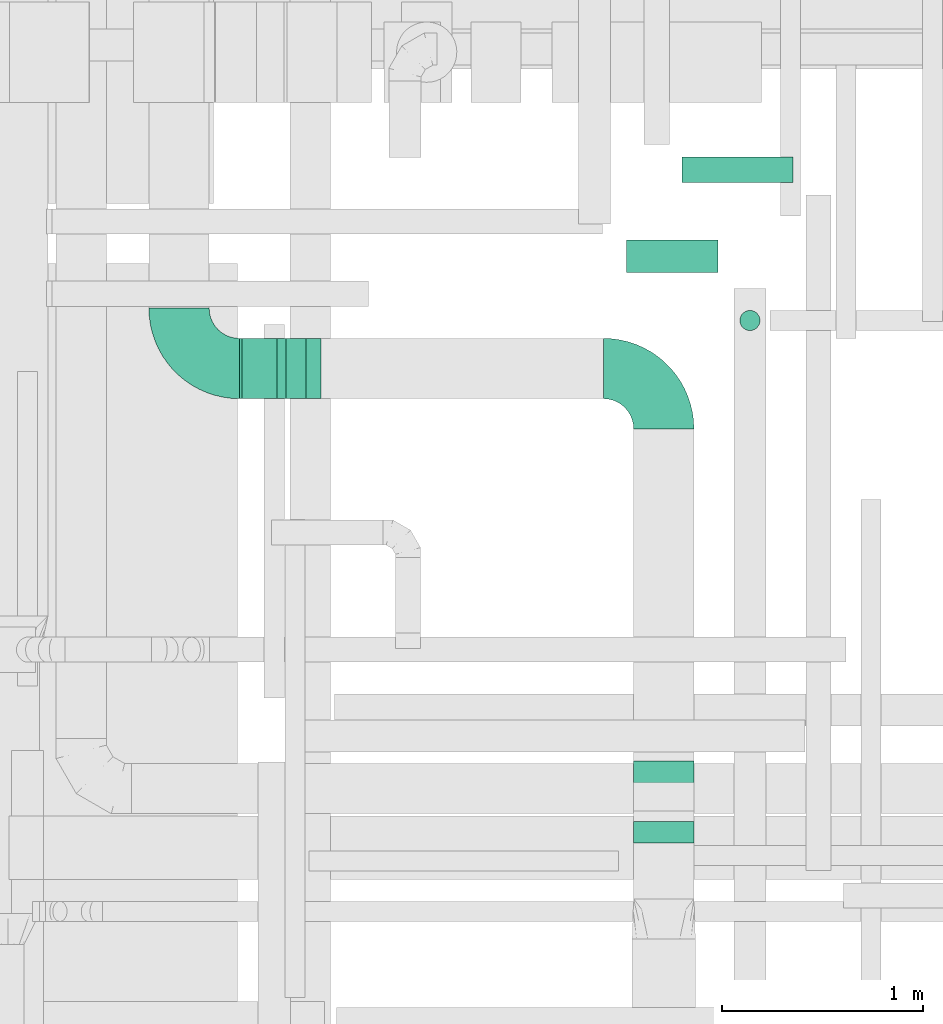
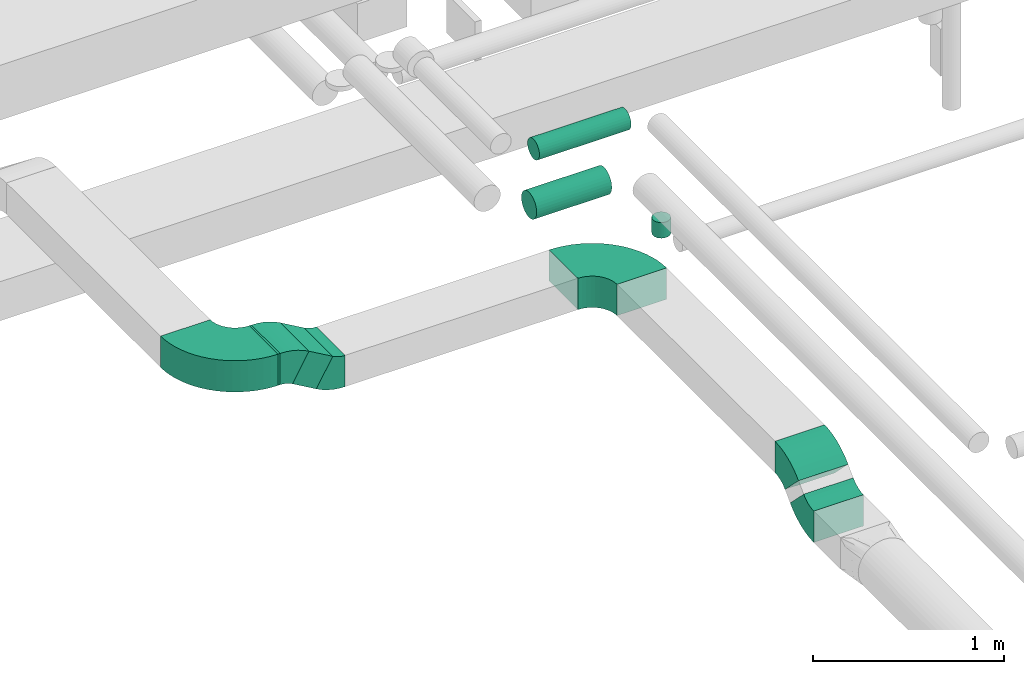
# One storey, part 125 of 337: 6 flow fittings, 5 flow segments.
"""IFC2X3 building model written with IfcOpenShell, lengths in millimetres."""

from ifc_helpers import new_model, entity, si_unit, converted_unit, derived_unit, direction, frame, frame_2d, origin, origin_2d_with_axis, place, context, subcontext, project, spatial, polyline, circle_curve, parameter, trimmed, segment, composite_curve, rectangle, circle, outline, extrude, source, transform, mapped, material, type_object, type_shapes, element, save


model = new_model("IFC2X3")

# Units and contexts
model_context = context("Model", 3, precision=0.01, world=origin(), true_north=direction((6.12303176911189e-17, 1.0)))
body_context = subcontext(model_context, "Body", "Model", "MODEL_VIEW")
ifc_project = project(units=[si_unit("LENGTHUNIT", "METRE", prefix="MILLI"), si_unit("AREAUNIT", "SQUARE_METRE"), si_unit("VOLUMEUNIT", "CUBIC_METRE"), converted_unit("PLANEANGLEUNIT", "DEGREE", entity("IfcRatioMeasure", 0.0174532925199433), si_unit("PLANEANGLEUNIT", "RADIAN"), dimensions=[0, 0, 0, 0, 0, 0, 0]), si_unit("MASSUNIT", "GRAM", prefix="KILO"), derived_unit("MASSDENSITYUNIT", [(si_unit("MASSUNIT", "GRAM", prefix="KILO"), 1), (si_unit("LENGTHUNIT", "METRE"), -3)]), derived_unit("MOMENTOFINERTIAUNIT", [(si_unit("LENGTHUNIT", "METRE"), 4)]), si_unit("TIMEUNIT", "SECOND"), si_unit("FREQUENCYUNIT", "HERTZ"), si_unit("THERMODYNAMICTEMPERATUREUNIT", "DEGREE_CELSIUS"), derived_unit("THERMALTRANSMITTANCEUNIT", [(si_unit("MASSUNIT", "GRAM", prefix="KILO"), 1), (si_unit("THERMODYNAMICTEMPERATUREUNIT", "KELVIN"), -1), (si_unit("TIMEUNIT", "SECOND"), -3)]), derived_unit("VOLUMETRICFLOWRATEUNIT", [(si_unit("LENGTHUNIT", "METRE"), 3), (si_unit("TIMEUNIT", "SECOND"), -1)]), derived_unit("MASSFLOWRATEUNIT", [(si_unit("MASSUNIT", "GRAM", prefix="KILO"), 1), (si_unit("TIMEUNIT", "SECOND"), -1)]), derived_unit("ROTATIONALFREQUENCYUNIT", [(si_unit("TIMEUNIT", "SECOND"), -1)]), si_unit("ELECTRICCURRENTUNIT", "AMPERE"), si_unit("ELECTRICVOLTAGEUNIT", "VOLT"), si_unit("POWERUNIT", "WATT"), si_unit("FORCEUNIT", "NEWTON", prefix="KILO"), si_unit("ILLUMINANCEUNIT", "LUX"), si_unit("LUMINOUSFLUXUNIT", "LUMEN"), si_unit("LUMINOUSINTENSITYUNIT", "CANDELA"), derived_unit("USERDEFINED", [(si_unit("MASSUNIT", "GRAM", prefix="KILO"), -1), (si_unit("LENGTHUNIT", "METRE"), -2), (si_unit("TIMEUNIT", "SECOND"), 3), (si_unit("LUMINOUSFLUXUNIT", "LUMEN"), 1)]), derived_unit("LINEARVELOCITYUNIT", [(si_unit("LENGTHUNIT", "METRE"), 1), (si_unit("TIMEUNIT", "SECOND"), -1)]), si_unit("PRESSUREUNIT", "PASCAL"), derived_unit("USERDEFINED", [(si_unit("LENGTHUNIT", "METRE"), -2), (si_unit("MASSUNIT", "GRAM", prefix="KILO"), 1), (si_unit("TIMEUNIT", "SECOND"), -2)]), derived_unit("LINEARFORCEUNIT", [(si_unit("MASSUNIT", "GRAM", prefix="KILO"), 1), (si_unit("LENGTHUNIT", "METRE"), 1), (si_unit("TIMEUNIT", "SECOND"), -2), (si_unit("LENGTHUNIT", "METRE"), -1)]), derived_unit("PLANARFORCEUNIT", [(si_unit("MASSUNIT", "GRAM", prefix="KILO"), 1), (si_unit("LENGTHUNIT", "METRE"), 1), (si_unit("TIMEUNIT", "SECOND"), -2), (si_unit("LENGTHUNIT", "METRE"), -2)])], contexts=[model_context])

# Site, building, storey
site_placement = place(None, origin())
site = spatial("IfcSite", under=ifc_project, at=site_placement, CompositionType="ELEMENT")
building_placement = place(site_placement, origin())
building = spatial("IfcBuilding", under=site, at=building_placement, CompositionType="ELEMENT")
storey_placement = place(building_placement, origin())
storey = spatial("IfcBuildingStorey", under=building, at=storey_placement, CompositionType="ELEMENT", Elevation=0.0)

# Flow segments
duct_segment_type_1 = type_object("IfcDuctSegmentType", PredefinedType="NOTDEFINED")
flow_segment_1_placement = place(storey_placement, frame((30777.78, 6460.62, -650.0)))
element("IfcFlowSegment", 1, at=flow_segment_1_placement, inside=storey, type_object=duct_segment_type_1, context=body_context, shape_type="SweptSolid", body=[
    extrude(rectangle(XDim=12.3963436673465, YDim=300.0, at=origin_2d_with_axis()), frame((6.2, 150.0, 0.0)), (0.0, 0.0, 1.0), 200.0),
])
flow_segment_2_placement = place(storey_placement, frame((30865.17, 6460.62, -753.11)))
element("IfcFlowSegment", 2, at=flow_segment_2_placement, inside=storey, type_object=duct_segment_type_1, context=body_context, shape_type="SweptSolid", body=[
    extrude(rectangle(XDim=200.0, YDim=166.025407859737, at=frame_2d((0.0, 0.0), x_axis=(0.0, 1.0))), frame((121.89, 0.0, 128.11), z_axis=(0.0, 1.0, 0.0), x_axis=(-0.866025374628233, 0.0, 0.500000050500025)), (0.0, 0.0, 1.0), 299.999999999999),
])
duct_segment_type_2 = type_object("IfcDuctSegmentType", PredefinedType="NOTDEFINED")
flow_segment_3_placement = place(storey_placement, frame((32704.11, 7087.93, -681.6)))
element("IfcFlowSegment", 3, at=flow_segment_3_placement, inside=storey, type_object=duct_segment_type_2, context=body_context, shape_type="SweptSolid", body=[
    extrude(circle(Radius=80.0, at=origin_2d_with_axis()), frame((0.0, 81.6, 81.6), z_axis=(1.0, 0.0, 0.0), x_axis=(0.0, -1.0, 0.0)), (0.0, 0.0, 1.0), 454.238410000027),
])
flow_segment_4_placement = place(storey_placement, frame((33266.76, 6797.92, -800.0)))
element("IfcFlowSegment", 4, at=flow_segment_4_placement, inside=storey, type_object=duct_segment_type_2, context=body_context, shape_type="SweptSolid", body=[
    extrude(circle(Radius=50.0, at=origin_2d_with_axis()), frame((51.6, 51.6, 0.0), z_axis=(0.0, 0.0, 1.0), x_axis=(0.0, -1.0, 0.0)), (0.0, 0.0, 1.0), 100.000000000011),
])
flow_segment_5_placement = place(storey_placement, frame((32979.47, 7535.68, -664.1)))
element("IfcFlowSegment", 5, at=flow_segment_5_placement, inside=storey, type_object=duct_segment_type_2, context=body_context, shape_type="SweptSolid", body=[
    extrude(circle(Radius=62.5, at=origin_2d_with_axis()), frame((0.0, 64.1, 64.1), z_axis=(1.0, 0.0, 0.0), x_axis=(0.0, 1.0, 0.0)), (0.0, 0.0, 1.0), 554.175640000027),
])

# Flow fittings
ifc_material = material()
duct_fitting_type_1 = type_object("IfcDuctFittingType", PredefinedType="NOTDEFINED", material=ifc_material)
shared_shape_1 = source(origin(), body_context, "Body", "SweptSolid", [
    extrude(outline(composite_curve([segment(polyline([(-300.0, -150.0), (0.0, -150.0)]), True, "CONTINUOUS"), segment(trimmed(circle_curve(frame_2d((150.0, -150.0), x_axis=(0.0, 1.0)), 150.0), [parameter(0.0)], [parameter(90.0)], True, "PARAMETER"), False, "CONTINUOUS"), segment(polyline([(150.0, 0.0), (150.0, 300.0)]), True, "CONTINUOUS"), segment(trimmed(circle_curve(frame_2d((150.0, -150.0), x_axis=(0.0, 1.0)), 450.0), [parameter(0.0)], [parameter(90.0000000000001)], True, "PARAMETER"), True, "CONTINUOUS")], self_intersect=False)), frame((-150.0, 150.0, -100.0), z_axis=(0.0, 0.0, 1.0), x_axis=(-1.0, 0.0, 0.0)), (0.0, 0.0, 1.0), 200.0),
])
type_shapes(duct_fitting_type_1, [shared_shape_1])
for number, where, z_axis, x_axis in (
    (6, (32889.74, 6610.62, -700.0), (0.0, 0.0, 1.0), (0.0, 1.0, 0.0)),
    (7, (30477.78, 6610.62, -550.0), (0.0, 0.0, 1.0), (0.0, -1.0, 0.0)),
):
    element("IfcFlowFitting", number, at=place(storey_placement, frame(where, z_axis=z_axis, x_axis=x_axis)), inside=storey, type_object=duct_fitting_type_1, material=ifc_material, context=body_context, shape_type="MappedRepresentation", body=[
        mapped(shared_shape_1, transform((0.0, 0.0, 0.0), scale=1.0)),
    ])
duct_fitting_type_2 = type_object("IfcDuctFittingType", PredefinedType="NOTDEFINED", material=ifc_material)
shared_shape_2 = source(origin(), body_context, "Body", "SweptSolid", [
    extrude(outline(composite_curve([segment(polyline([(-136.61, -88.39), (63.39, -88.39)]), True, "CONTINUOUS"), segment(trimmed(circle_curve(frame_2d((213.39, -88.39), x_axis=(-0.707106781186546, 0.707106781186546)), 150.0), [parameter(0.0)], [parameter(45.0)], True, "PARAMETER"), False, "CONTINUOUS"), segment(polyline([(107.32, 17.68), (-34.1, 159.1)]), True, "CONTINUOUS"), segment(trimmed(circle_curve(frame_2d((213.39, -88.39), x_axis=(-0.707106781186546, 0.707106781186546)), 350.0), [parameter(0.0)], [parameter(45.0)], True, "PARAMETER"), True, "CONTINUOUS")], self_intersect=False)), frame((-15.17, 36.61, -150.0), z_axis=(0.0, 0.0, 1.0), x_axis=(-0.707106781186547, 0.707106781186548, 0.0)), (0.0, 0.0, 1.0), 300.0),
])
type_shapes(duct_fitting_type_2, [shared_shape_2])
for number, where, z_axis, x_axis in (
    (8, (32889.74, 4554.18, -700.0), (1.0, 0.0, 0.0), (0.0, -1.0, 0.0)),
    (9, (32889.74, 4354.18, -900.0), (-1.0, 0.0, 0.0), (0.0, -0.707106781186532, -0.707106781186563)),
):
    element("IfcFlowFitting", number, at=place(storey_placement, frame(where, z_axis=z_axis, x_axis=x_axis)), inside=storey, type_object=duct_fitting_type_2, material=ifc_material, context=body_context, shape_type="MappedRepresentation", body=[
        mapped(shared_shape_2, transform((0.0, 0.0, 0.0), scale=1.0)),
    ])
duct_fitting_type_3 = type_object("IfcDuctFittingType", PredefinedType="NOTDEFINED", material=ifc_material)
shared_shape_3 = source(origin(), body_context, "Body", "SweptSolid", [
    extrude(outline(composite_curve([segment(polyline([(-116.75, -62.5), (83.25, -62.5)]), True, "CONTINUOUS"), segment(trimmed(circle_curve(frame_2d((233.25, -62.5), x_axis=(-0.866025374628236, 0.500000050500022)), 150.0), [parameter(0.0)], [parameter(30.0000033410545)], True, "PARAMETER"), False, "CONTINUOUS"), segment(polyline([(103.35, 12.5), (-69.86, 112.5)]), True, "CONTINUOUS"), segment(trimmed(circle_curve(frame_2d((233.25, -62.5), x_axis=(-0.866025374628236, 0.500000050500022)), 350.0), [parameter(0.0)], [parameter(30.0000033410545)], True, "PARAMETER"), True, "CONTINUOUS")], self_intersect=False)), frame((-4.49, 16.75, -150.0), z_axis=(0.0, 0.0, 1.0), x_axis=(-0.500000050500021, 0.866025374628236, 0.0)), (0.0, 0.0, 1.0), 300.0),
])
type_shapes(duct_fitting_type_3, [shared_shape_3])
for number, where, z_axis, x_axis in (
    (10, (31116.97, 6610.62, -700.0), (0.0, 1.0, 0.0), (-1.0, 0.0, 0.0)),
    (11, (30857.16, 6610.62, -550.0), (0.0, -1.0, 0.0), (-0.86602537462819, 0.0, 0.500000050500101)),
):
    element("IfcFlowFitting", number, at=place(storey_placement, frame(where, z_axis=z_axis, x_axis=x_axis)), inside=storey, type_object=duct_fitting_type_3, material=ifc_material, context=body_context, shape_type="MappedRepresentation", body=[
        mapped(shared_shape_3, transform((0.0, 0.0, 0.0), scale=1.0)),
    ])

save(model, "model.ifc")
